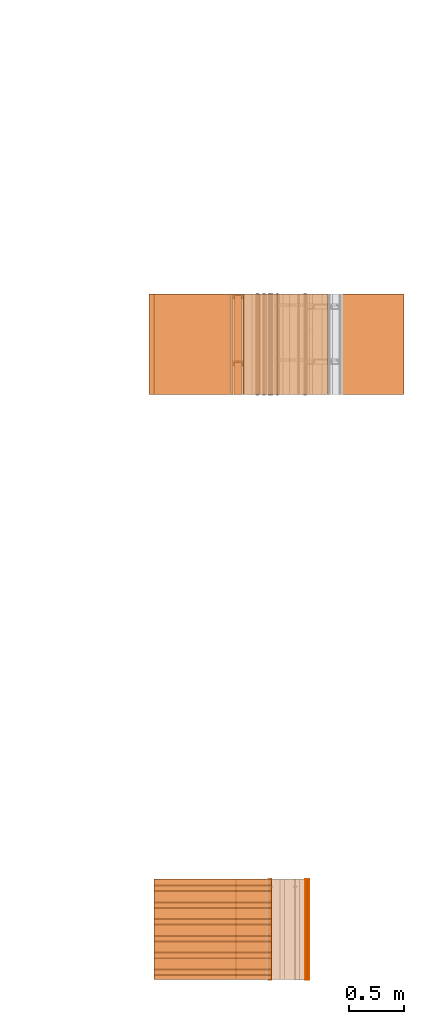
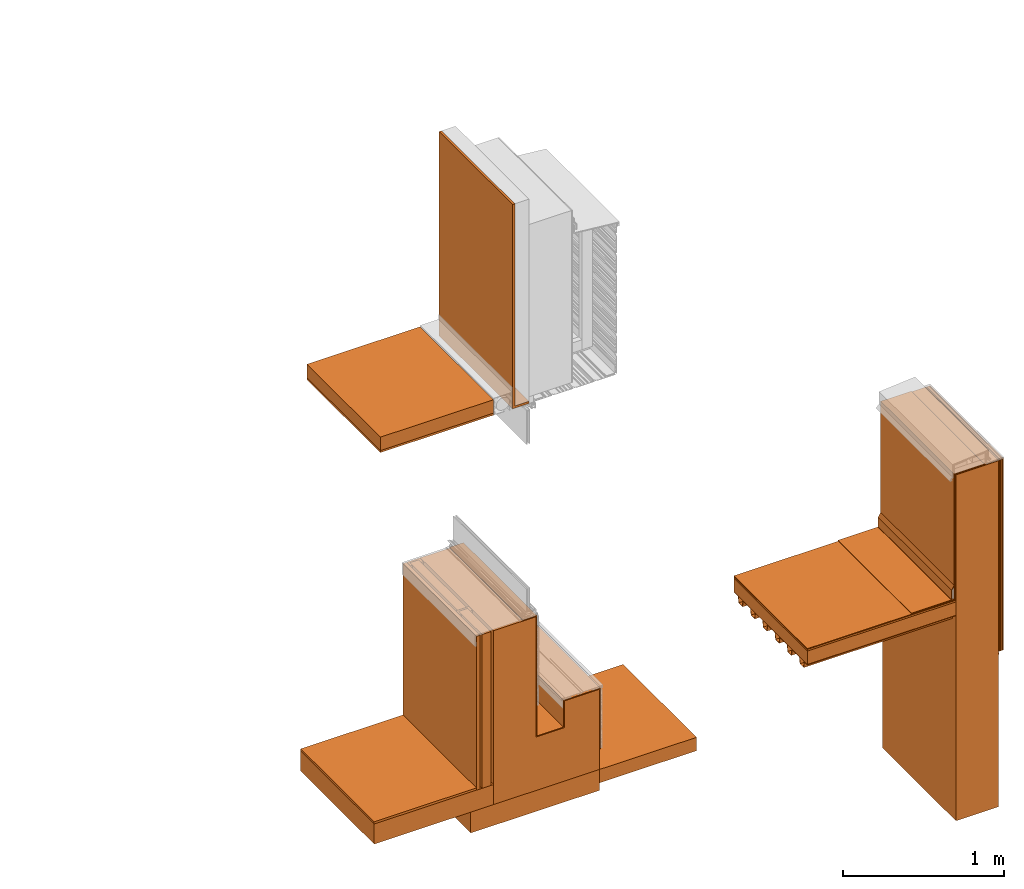
# One storey, part 1 of 36: 26 proxies.
"""IFC2X3 building model written with IfcOpenShell, lengths in feet."""

from ifc_helpers import new_model, entity, si_unit, converted_unit, derived_unit, direction, frame, frame_2d, origin, origin_2d_with_axis, place, context, subcontext, project, spatial, polyline, circle_curve, parameter, trimmed, segment, composite_curve, rectangle, outline, extrude, source, transform, mapped, material, type_object, type_shapes, element, save


model = new_model("IFC2X3")

# Units and contexts
model_context = context("Model", 3, precision=0.0001, world=origin(), true_north=direction((6.12303176911189e-17, 1.0)))
body_context = subcontext(model_context, "Body", "Model", "MODEL_VIEW")
ifc_project = project(units=[converted_unit("LENGTHUNIT", "FOOT", entity("IfcRatioMeasure", 0.3048), si_unit("LENGTHUNIT", "METRE"), dimensions=[1, 0, 0, 0, 0, 0, 0]), converted_unit("AREAUNIT", "SQUARE FOOT", entity("IfcRatioMeasure", 0.09290304), si_unit("AREAUNIT", "SQUARE_METRE"), dimensions=[2, 0, 0, 0, 0, 0, 0]), converted_unit("VOLUMEUNIT", "CUBIC FOOT", entity("IfcRatioMeasure", 0.028316846592), si_unit("VOLUMEUNIT", "CUBIC_METRE"), dimensions=[3, 0, 0, 0, 0, 0, 0]), converted_unit("PLANEANGLEUNIT", "DEGREE", entity("IfcRatioMeasure", 0.0174532925199433), si_unit("PLANEANGLEUNIT", "RADIAN"), dimensions=[0, 0, 0, 0, 0, 0, 0]), si_unit("MASSUNIT", "GRAM", prefix="KILO"), derived_unit("MASSDENSITYUNIT", [(si_unit("MASSUNIT", "GRAM", prefix="KILO"), 1), (si_unit("LENGTHUNIT", "METRE"), -3)]), si_unit("TIMEUNIT", "SECOND"), si_unit("FREQUENCYUNIT", "HERTZ"), si_unit("THERMODYNAMICTEMPERATUREUNIT", "DEGREE_CELSIUS"), derived_unit("THERMALTRANSMITTANCEUNIT", [(si_unit("MASSUNIT", "GRAM", prefix="KILO"), 1), (si_unit("THERMODYNAMICTEMPERATUREUNIT", "KELVIN"), -1), (si_unit("TIMEUNIT", "SECOND"), -3)]), derived_unit("VOLUMETRICFLOWRATEUNIT", [(si_unit("LENGTHUNIT", "METRE"), 3), (si_unit("TIMEUNIT", "SECOND"), -1)]), si_unit("ELECTRICCURRENTUNIT", "AMPERE"), si_unit("ELECTRICVOLTAGEUNIT", "VOLT"), si_unit("POWERUNIT", "WATT"), si_unit("FORCEUNIT", "NEWTON"), si_unit("ILLUMINANCEUNIT", "LUX"), si_unit("LUMINOUSFLUXUNIT", "LUMEN"), si_unit("LUMINOUSINTENSITYUNIT", "CANDELA"), derived_unit("USERDEFINED", [(si_unit("MASSUNIT", "GRAM", prefix="KILO"), -1), (si_unit("LENGTHUNIT", "METRE"), -2), (si_unit("TIMEUNIT", "SECOND"), 3), (si_unit("LUMINOUSFLUXUNIT", "LUMEN"), 1)]), derived_unit("LINEARVELOCITYUNIT", [(si_unit("LENGTHUNIT", "METRE"), 1), (si_unit("TIMEUNIT", "SECOND"), -1)]), si_unit("PRESSUREUNIT", "PASCAL"), derived_unit("USERDEFINED", [(si_unit("LENGTHUNIT", "METRE"), -2), (si_unit("MASSUNIT", "GRAM", prefix="KILO"), 1), (si_unit("TIMEUNIT", "SECOND"), -2)])], contexts=[model_context])

# Site, building, storey
site_placement = place(None, origin())
site = spatial("IfcSite", under=ifc_project, at=site_placement, CompositionType="ELEMENT")
building_placement = place(site_placement, origin())
building = spatial("IfcBuilding", under=site, at=building_placement, CompositionType="ELEMENT")
storey_placement = place(building_placement, origin())
storey = spatial("IfcBuildingStorey", under=building, at=storey_placement, Name="Level 1", CompositionType="ELEMENT", Elevation=0.0)

# Proxies
ifc_material_1 = material()
building_element_proxy_type_1 = type_object("IfcBuildingElementProxyType", PredefinedType="NOTDEFINED", material=ifc_material_1)
shared_shape_1 = source(origin(), body_context, "Body", "SweptSolid", [
    extrude(rectangle(XDim=2.99999999999999, YDim=3.50495130620079, at=frame_2d((7.105427357601e-15, -7.105427357601e-15), x_axis=(1.0, 0.0))), frame((121.624397761532, -80.1652000961286, 15.0), z_axis=(0.0, 0.0, 1.0), x_axis=(0.0, -1.0, 0.0)), (0.0, 0.0, 1.0), 0.333333333333337),
])
type_shapes(building_element_proxy_type_1, [shared_shape_1])
proxy_1_placement = place(storey_placement, origin())
element("IfcBuildingElementProxy", 1, at=proxy_1_placement, inside=storey, type_object=building_element_proxy_type_1, material=ifc_material_1, context=body_context, shape_type="MappedRepresentation", body=[
    mapped(shared_shape_1, transform((0.0, 0.0, 0.0), scale=1.0)),
])
ifc_material_2 = material(Name="_EXISTING CAST-IN-PLACE CONCRETE")
building_element_proxy_type_2 = type_object("IfcBuildingElementProxyType", PredefinedType="NOTDEFINED", material=ifc_material_2)
shared_shape_2 = source(origin(), body_context, "Body", "SweptSolid", [
    extrude(rectangle(XDim=2.99999999999999, YDim=0.999999999999986, at=frame_2d((7.105427357601e-15, 7.105427357601e-15), x_axis=(1.0, 0.0))), frame((123.876873414633, -80.1652000961286, 9.875), z_axis=(0.0, 0.0, 1.0), x_axis=(0.0, -1.0, 0.0)), (0.0, 0.0, 1.0), 8.625),
])
type_shapes(building_element_proxy_type_2, [shared_shape_2])
proxy_2_placement = place(storey_placement, origin())
element("IfcBuildingElementProxy", 2, at=proxy_2_placement, inside=storey, type_object=building_element_proxy_type_2, material=ifc_material_2, context=body_context, shape_type="MappedRepresentation", body=[
    mapped(shared_shape_2, transform((0.0, 0.0, 0.0), scale=1.0)),
])
building_element_proxy_type_3 = type_object("IfcBuildingElementProxyType", PredefinedType="NOTDEFINED", material=ifc_material_2)
shared_shape_3 = source(origin(), body_context, "Body", "SweptSolid", [
    extrude(outline(composite_curve([segment(polyline([(-2.14143887679974, -0.784598214307451), (-2.13102221013308, -0.784598214307451)]), True, "CONTINUOUS"), segment(polyline([(-2.13102221013308, -0.784598214307451), (-2.13102221013308, -0.0762648809741222)]), True, "CONTINUOUS"), segment(polyline([(-2.13102221013308, -0.0762648809741222), (0.63017533183543, -0.0762648809412951)]), True, "CONTINUOUS"), segment(polyline([(0.63017533183543, -0.0762648809412951), (0.733917958331489, -0.0163690476079665)]), True, "CONTINUOUS"), segment(polyline([(0.733917958331489, -0.0163690476079665), (0.959969644729002, -0.0163690476079665)]), True, "CONTINUOUS"), segment(trimmed(circle_curve(frame_2d((0.959969644729002, 0.00446428571936508), x_axis=(0.0, -1.0)), 0.0208333333333333), [parameter(0.0)], [parameter(90.0000000000001)], True, "PARAMETER"), True, "CONTINUOUS"), segment(polyline([(0.980802978062336, 0.00446428571936508), (0.980802978062462, 0.944568452392019)]), True, "CONTINUOUS"), segment(polyline([(0.980802978062462, 0.944568452392019), (0.970386311395799, 0.944568452392019)]), True, "CONTINUOUS"), segment(polyline([(0.970386311395799, 0.944568452392019), (0.970386311395799, 0.00446428571936508)]), True, "CONTINUOUS"), segment(trimmed(circle_curve(frame_2d((0.959969644729002, 0.00446428571936508), x_axis=(0.0, -1.0)), 0.0104166666666667), [parameter(0.0)], [parameter(90.0000000000001)], True, "PARAMETER"), False, "CONTINUOUS"), segment(polyline([(0.959969644729002, -0.00595238094730632), (0.731126820910234, -0.00595238094132355)]), True, "CONTINUOUS"), segment(polyline([(0.731126820910234, -0.00595238094132355), (0.627384194414171, -0.0658482142746379)]), True, "CONTINUOUS"), segment(polyline([(0.627384194414171, -0.0658482142746379), (-2.14143887679974, -0.0658482143074366)]), True, "CONTINUOUS"), segment(polyline([(-2.14143887679974, -0.0658482143074366), (-2.14143887679974, -0.784598214307451)]), True, "CONTINUOUS")], self_intersect=False)), frame((123.269358533659, -81.6652000961286, 16.3898111232003), z_axis=(0.0, 1.0, 0.0), x_axis=(0.0, 0.0, -1.0)), (0.0, 0.0, 1.0), 3.0),
])
type_shapes(building_element_proxy_type_3, [shared_shape_3])
proxy_3_placement = place(storey_placement, origin())
element("IfcBuildingElementProxy", 3, at=proxy_3_placement, inside=storey, type_object=building_element_proxy_type_3, material=ifc_material_2, context=body_context, shape_type="MappedRepresentation", body=[
    mapped(shared_shape_3, transform((0.0, 0.0, 0.0), scale=1.0)),
])
ifc_material_3 = material()
building_element_proxy_type_4 = type_object("IfcBuildingElementProxyType", PredefinedType="NOTDEFINED", material=ifc_material_3)
shared_shape_4 = source(origin(), body_context, "Body", "SweptSolid", [
    extrude(rectangle(XDim=0.0208333333333712, YDim=3.0, at=origin_2d_with_axis()), frame((123.366456747966, -80.1652000961286, 15.375), z_axis=(0.0, 0.0, 1.0), x_axis=(-1.0, 0.0, 0.0)), (0.0, 0.0, 1.0), 3.125),
])
type_shapes(building_element_proxy_type_4, [shared_shape_4])
proxy_4_placement = place(storey_placement, origin())
element("IfcBuildingElementProxy", 4, at=proxy_4_placement, inside=storey, type_object=building_element_proxy_type_4, material=ifc_material_3, context=body_context, shape_type="MappedRepresentation", body=[
    mapped(shared_shape_4, transform((0.0, 0.0, 0.0), scale=1.0)),
])
ifc_material_4 = material()
building_element_proxy_type_5 = type_object("IfcBuildingElementProxyType", PredefinedType="NOTDEFINED", material=ifc_material_4)
shared_shape_5 = source(origin(), body_context, "Body", "SweptSolid", [
    extrude(outline(polyline([(1.64442176403685, 0.957543218787396), (1.66517036318022, 0.957543218787396), (1.70388969748723, 0.984654788509743), (1.70090232021708, 0.988921205408832), (1.66352818199028, 0.962751552121041), (1.6427795828469, 0.962751552121037), (-2.27369147607305, -1.77959100308735), (-2.73388175054224, -1.12237117906065), (-2.73814816744133, -1.12535855633081), (-2.27497051570199, -1.7868447972566), (1.64442176403685, 0.957543218787396)])), frame((124.22325365897, -81.6652000961286, 15.627186180336), z_axis=(0.0, 1.0, 0.0), x_axis=(0.573576435870009, 0.0, -0.819152044625818)), (0.0, 0.0, 1.0), 3.0),
])
type_shapes(building_element_proxy_type_5, [shared_shape_5])
proxy_5_placement = place(storey_placement, origin())
element("IfcBuildingElementProxy", 5, at=proxy_5_placement, inside=storey, type_object=building_element_proxy_type_5, material=ifc_material_4, context=body_context, shape_type="MappedRepresentation", body=[
    mapped(shared_shape_5, transform((0.0, 0.0, 0.0), scale=1.0)),
])
building_element_proxy_type_6 = type_object("IfcBuildingElementProxyType", PredefinedType="NOTDEFINED", material=ifc_material_4)
shared_shape_6 = source(origin(), body_context, "Body", "SweptSolid", [
    extrude(rectangle(XDim=0.0156249999999858, YDim=2.99999999999999, at=frame_2d((7.105427357601e-15, 7.105427357601e-15), x_axis=(1.0, 0.0))), frame((124.473227581299, -80.1652000961286, 13.744164864019), z_axis=(0.0, 0.0, 1.0), x_axis=(-1.0, 0.0, 0.0)), (0.0, 0.0, 1.0), 4.7714601359811),
])
type_shapes(building_element_proxy_type_6, [shared_shape_6])
proxy_6_placement = place(storey_placement, origin())
element("IfcBuildingElementProxy", 6, at=proxy_6_placement, inside=storey, type_object=building_element_proxy_type_6, material=ifc_material_4, context=body_context, shape_type="MappedRepresentation", body=[
    mapped(shared_shape_6, transform((0.0, 0.0, 0.0), scale=1.0)),
])
ifc_material_5 = material()
building_element_proxy_type_7 = type_object("IfcBuildingElementProxyType", PredefinedType="NOTDEFINED", material=ifc_material_5)
shared_shape_7 = source(origin(), body_context, "Body", "SweptSolid", [
    extrude(rectangle(XDim=0.0196850393700885, YDim=2.99999999999999, at=frame_2d((7.105427357601e-15, 7.105427357601e-15), x_axis=(1.0, 0.0))), frame((124.490882600984, -80.1652000961286, 13.744164864019), z_axis=(0.0, 0.0, 1.0), x_axis=(-1.0, 0.0, 0.0)), (0.0, 0.0, 1.0), 4.7714601359811),
])
type_shapes(building_element_proxy_type_7, [shared_shape_7])
proxy_7_placement = place(storey_placement, origin())
element("IfcBuildingElementProxy", 7, at=proxy_7_placement, inside=storey, type_object=building_element_proxy_type_7, material=ifc_material_5, context=body_context, shape_type="MappedRepresentation", body=[
    mapped(shared_shape_7, transform((0.0, 0.0, 0.0), scale=1.0)),
])
ifc_material_6 = material()
building_element_proxy_type_8 = type_object("IfcBuildingElementProxyType", PredefinedType="NOTDEFINED", material=ifc_material_6)
shared_shape_8 = source(origin(), body_context, "Body", "SweptSolid", [
    extrude(rectangle(XDim=0.0416666666666714, YDim=2.99999999999999, at=frame_2d((7.105427357601e-15, 7.105427357601e-15), x_axis=(1.0, 0.0))), frame((124.444581747966, -80.1652000961286, 13.744164864019), z_axis=(0.0, 0.0, 1.0), x_axis=(-1.0, 0.0, 0.0)), (0.0, 0.0, 1.0), 4.7714601359811),
])
type_shapes(building_element_proxy_type_8, [shared_shape_8])
proxy_8_placement = place(storey_placement, origin())
element("IfcBuildingElementProxy", 8, at=proxy_8_placement, inside=storey, type_object=building_element_proxy_type_8, material=ifc_material_6, context=body_context, shape_type="MappedRepresentation", body=[
    mapped(shared_shape_8, transform((0.0, 0.0, 0.0), scale=1.0)),
])
ifc_material_7 = material()
building_element_proxy_type_9 = type_object("IfcBuildingElementProxyType", PredefinedType="NOTDEFINED", material=ifc_material_7)
shared_shape_9 = source(origin(), body_context, "Body", "SweptSolid", [
    extrude(rectangle(XDim=0.020833333333357, YDim=2.99999999999999, at=frame_2d((7.105427357601e-15, 7.105427357601e-15), x_axis=(1.0, 0.0))), frame((124.413331747966, -80.1652000961286, 13.744164864019), z_axis=(0.0, 0.0, 1.0), x_axis=(-1.0, 0.0, 0.0)), (0.0, 0.0, 1.0), 4.7714601359811),
])
type_shapes(building_element_proxy_type_9, [shared_shape_9])
proxy_9_placement = place(storey_placement, origin())
element("IfcBuildingElementProxy", 9, at=proxy_9_placement, inside=storey, type_object=building_element_proxy_type_9, material=ifc_material_7, context=body_context, shape_type="MappedRepresentation", body=[
    mapped(shared_shape_9, transform((0.0, 0.0, 0.0), scale=1.0)),
])
building_element_proxy_type_10 = type_object("IfcBuildingElementProxyType", PredefinedType="NOTDEFINED", material=ifc_material_7)
shared_shape_10 = source(origin(), body_context, "Body", "SweptSolid", [
    extrude(rectangle(XDim=0.020833333333357, YDim=2.99999999999999, at=frame_2d((-7.105427357601e-15, 7.105427357601e-15), x_axis=(1.0, 0.0))), frame((124.392498414633, -80.1652000961286, 13.744164864019), z_axis=(0.0, 0.0, 1.0), x_axis=(-1.0, 0.0, 0.0)), (0.0, 0.0, 1.0), 4.7714601359811),
])
type_shapes(building_element_proxy_type_10, [shared_shape_10])
proxy_10_placement = place(storey_placement, origin())
element("IfcBuildingElementProxy", 10, at=proxy_10_placement, inside=storey, type_object=building_element_proxy_type_10, material=ifc_material_7, context=body_context, shape_type="MappedRepresentation", body=[
    mapped(shared_shape_10, transform((0.0, 0.0, 0.0), scale=1.0)),
])
building_element_proxy_type_11 = type_object("IfcBuildingElementProxyType", Name="Generic Models 7:Generic Models 7", PredefinedType="NOTDEFINED", material=ifc_material_7)
shared_shape_11 = source(origin(), body_context, "Body", "SweptSolid", [
    extrude(outline(polyline([(-0.304129554411825, -1.1372250122797), (-0.332958090772665, -1.29097720620095), (-0.184783389742921, -1.34856737340409), (-0.206226270170879, -1.46292940235079), (-0.195988018223653, -1.46484907459094), (-0.172951951341912, -1.34199005122424), (-0.321126652371658, -1.28439988402109), (-0.295484488918378, -1.14764167893981), (-0.136511631537817, -1.14764167893981), (-0.0808076838149492, -0.850553957757426), (-0.228982384844695, -0.792963790554283), (-0.203340221391418, -0.656205585473014), (-0.0443673640108565, -0.656205585473014), (0.0113365837120136, -0.359117864290615), (-0.136838117317732, -0.301527697087473), (-0.111195953864455, -0.164769492006203), (0.0477769035161064, -0.164769492006204), (0.103480851238976, 0.132318229176195), (-0.0446938497907691, 0.189908396379337), (-0.0190516863374923, 0.326666601460607), (0.139921171043069, 0.326666601460607), (0.195625118765937, 0.623754322642991), (0.0474504177361911, 0.681344489846134), (0.0730925811894706, 0.818102694927417), (0.232065438570032, 0.818102694927417), (0.287769386292902, 1.11519041610982), (0.139594685263157, 1.17278058331296), (0.165236848716436, 1.30953878839424), (0.324209706096995, 1.30953878839423), (0.356877586938122, 1.48376748620991), (0.346639334990895, 1.48568715845005), (0.315564640603549, 1.31995545505436), (0.156591783222989, 1.31995545505436), (0.127763246862152, 1.16620326113312), (0.275937947891893, 1.10861309392996), (0.223420373076586, 0.828519361587546), (0.0644475156960263, 0.828519361587546), (0.0356189793351888, 0.674767167666309), (0.183793680364933, 0.617177000463167), (0.131276105549623, 0.337083268120735), (-0.0276967518309365, 0.337083268120735), (-0.056525288191774, 0.183331074199499), (0.0916494128379697, 0.125740906996357), (0.039131838022663, -0.154352825346061), (-0.119841019357897, -0.154352825346061), (-0.14866955571874, -0.308105019267325), (-0.000494854688995738, -0.365695186470467), (-0.0530124295043025, -0.645788918812885), (-0.21198528688486, -0.645788918812871), (-0.2408138232457, -0.799541112734122), (-0.092639122215956, -0.857131279937264), (-0.145156697031265, -1.1372250122797), (-0.304129554411825, -1.1372250122797)])), frame((119.871922108432, -80.1893223378911, 14.9226762820528), z_axis=(-1.0, 0.0, 0.0), x_axis=(0.0, 0.184288535053926, 0.982872186933621)), (0.0, 0.0, -1.0), 3.50495130618844),
])
type_shapes(building_element_proxy_type_11, [shared_shape_11])
proxy_11_placement = place(storey_placement, origin())
element("IfcBuildingElementProxy", 11, at=proxy_11_placement, inside=storey, type_object=building_element_proxy_type_11, material=ifc_material_7, ObjectType="Generic Models 7 : Generic Models 7:Generic Models 7", context=body_context, shape_type="MappedRepresentation", body=[
    mapped(shared_shape_11, transform((0.0, 0.0, 0.0), scale=1.0)),
])
building_element_proxy_type_12 = type_object("IfcBuildingElementProxyType", PredefinedType="NOTDEFINED", material=ifc_material_2)
shared_shape_12 = source(origin(), body_context, "Body", "SweptSolid", [
    extrude(rectangle(XDim=3.50495130620078, YDim=2.99999999999999, at=frame_2d((0.0, 7.105427357601e-15), x_axis=(1.0, 0.0))), frame((121.624397761532, -80.1652000961286, 15.3333333333333), z_axis=(0.0, 0.0, 1.0), x_axis=(-1.0, 0.0, 0.0)), (0.0, 0.0, 1.0), 0.0416666666666661),
])
type_shapes(building_element_proxy_type_12, [shared_shape_12])
proxy_12_placement = place(storey_placement, origin())
element("IfcBuildingElementProxy", 12, at=proxy_12_placement, inside=storey, type_object=building_element_proxy_type_12, material=ifc_material_2, context=body_context, shape_type="MappedRepresentation", body=[
    mapped(shared_shape_12, transform((0.0, 0.0, 0.0), scale=1.0)),
])
building_element_proxy_type_13 = type_object("IfcBuildingElementProxyType", PredefinedType="NOTDEFINED", material=ifc_material_2)
shared_shape_13 = source(origin(), body_context, "Body", "SweptSolid", [
    extrude(outline(composite_curve([segment(polyline([(-2.59746347963235, -0.0788704922763088), (-2.59746347963235, -0.0892871589429767)]), True, "CONTINUOUS"), segment(polyline([(-2.59746347963235, -0.0892871589429767), (0.855404493215005, -0.0892871589408841)]), True, "CONTINUOUS"), segment(trimmed(circle_curve(frame_2d((0.855404493215005, -0.0684538256075502), x_axis=(1.0, 0.0)), 0.0208333333333333), [parameter(270.0)], [parameter(0.0)], True, "PARAMETER"), True, "CONTINUOUS"), segment(polyline([(0.876237826535643, -0.0684538256075502), (0.876237826535643, 0.23661147682474)]), True, "CONTINUOUS"), segment(polyline([(0.876237826535643, 0.23661147682474), (0.865821159868986, 0.23661147682474)]), True, "CONTINUOUS"), segment(polyline([(0.865821159868986, 0.23661147682474), (0.865821159881676, -0.0684538256075502)]), True, "CONTINUOUS"), segment(trimmed(circle_curve(frame_2d((0.855404493215005, -0.0684538256075502), x_axis=(1.0, 0.0)), 0.0104166666666667), [parameter(270.0)], [parameter(0.0)], True, "PARAMETER"), False, "CONTINUOUS"), segment(polyline([(0.855404493215005, -0.0788704922763088), (-2.59746347963235, -0.0788704922763088)]), True, "CONTINUOUS")], self_intersect=False)), frame((122.469385588097, -81.6652000961286, 15.4723751039758), z_axis=(0.0, -1.0, 0.0), x_axis=(1.0, 0.0, 0.0)), (0.0, 0.0, -1.0), 3.0),
])
type_shapes(building_element_proxy_type_13, [shared_shape_13])
proxy_13_placement = place(storey_placement, origin())
element("IfcBuildingElementProxy", 13, at=proxy_13_placement, inside=storey, type_object=building_element_proxy_type_13, material=ifc_material_2, context=body_context, shape_type="MappedRepresentation", body=[
    mapped(shared_shape_13, transform((0.0, 0.0, 0.0), scale=1.0)),
])
building_element_proxy_type_14 = type_object("IfcBuildingElementProxyType", Name="Foundation block003", PredefinedType="NOTDEFINED", material=ifc_material_2)
shared_shape_14 = source(origin(), body_context, "Body", "SweptSolid", [
    extrude(rectangle(XDim=3.0, YDim=3.04223472971455, at=origin_2d_with_axis()), frame((123.522417672094, -62.7284331589239, -0.52083333333334), z_axis=(0.0, 0.0, 1.0), x_axis=(0.0, 1.0, 0.0)), (0.0, 0.0, 1.0), 0.52083333333334),
])
type_shapes(building_element_proxy_type_14, [shared_shape_14])
proxy_14_placement = place(storey_placement, origin())
element("IfcBuildingElementProxy", 14, at=proxy_14_placement, inside=storey, type_object=building_element_proxy_type_14, material=ifc_material_2, Name="Foundation block003:Foundation block003", ObjectType="Foundation block003", context=body_context, shape_type="MappedRepresentation", body=[
    mapped(shared_shape_14, transform((0.0, 0.0, 0.0), scale=1.0)),
])
building_element_proxy_type_15 = type_object("IfcBuildingElementProxyType", Name="Floor structure003", PredefinedType="NOTDEFINED", material=ifc_material_2)
shared_shape_15 = source(origin(), body_context, "Body", "SweptSolid", [
    extrude(rectangle(XDim=3.0, YDim=2.81767872375659, at=origin_2d_with_axis()), frame((121.134695675185, -62.7284331589239, 0.0), z_axis=(0.0, 0.0, 1.0), x_axis=(0.0, 1.0, 0.0)), (0.0, 0.0, 1.0), 0.500000000000003),
])
type_shapes(building_element_proxy_type_15, [shared_shape_15])
proxy_15_placement = place(storey_placement, origin())
element("IfcBuildingElementProxy", 15, at=proxy_15_placement, inside=storey, type_object=building_element_proxy_type_15, material=ifc_material_2, Name="Floor structure003:Floor structure003", ObjectType="Floor structure003", context=body_context, shape_type="MappedRepresentation", body=[
    mapped(shared_shape_15, transform((0.0, 0.0, 0.0), scale=1.0)),
])
building_element_proxy_type_16 = type_object("IfcBuildingElementProxyType", Name="Floor covering material003", PredefinedType="NOTDEFINED", material=ifc_material_2)
shared_shape_16 = source(origin(), body_context, "Body", "SweptSolid", [
    extrude(rectangle(XDim=3.0, YDim=2.41239199827757, at=origin_2d_with_axis()), frame((120.932052312446, -62.7284331589239, 0.500000000000003), z_axis=(0.0, 0.0, 1.0), x_axis=(0.0, 1.0, 0.0)), (0.0, 0.0, 1.0), 0.0564560977821521),
])
type_shapes(building_element_proxy_type_16, [shared_shape_16])
proxy_16_placement = place(storey_placement, origin())
element("IfcBuildingElementProxy", 16, at=proxy_16_placement, inside=storey, type_object=building_element_proxy_type_16, material=ifc_material_2, Name="Floor covering material003:Floor covering material003", ObjectType="Floor covering material003", context=body_context, shape_type="MappedRepresentation", body=[
    mapped(shared_shape_16, transform((0.0, 0.0, 0.0), scale=1.0)),
])
building_element_proxy_type_17 = type_object("IfcBuildingElementProxyType", Name="Sidewalk pavement003", PredefinedType="NOTDEFINED", material=ifc_material_2)
shared_shape_17 = source(origin(), body_context, "Body", "SweptSolid", [
    extrude(rectangle(XDim=3.0, YDim=2.28466369050525, at=origin_2d_with_axis()), frame((126.185866882313, -62.7284331589239, -0.333333333333327), z_axis=(0.0, 0.0, 1.0), x_axis=(0.0, 1.0, 0.0)), (0.0, 0.0, 1.0), 0.333333333333327),
])
type_shapes(building_element_proxy_type_17, [shared_shape_17])
proxy_17_placement = place(storey_placement, origin())
element("IfcBuildingElementProxy", 17, at=proxy_17_placement, inside=storey, type_object=building_element_proxy_type_17, material=ifc_material_2, Name="Sidewalk pavement003:Sidewalk pavement003", ObjectType="Sidewalk pavement003", context=body_context, shape_type="MappedRepresentation", body=[
    mapped(shared_shape_17, transform((0.0, 0.0, 0.0), scale=1.0)),
])
building_element_proxy_type_18 = type_object("IfcBuildingElementProxyType", Name="Concrete wall004", PredefinedType="NOTDEFINED", material=ifc_material_2)
shared_shape_18 = source(origin(), body_context, "Body", "SweptSolid", [
    extrude(outline(polyline([(-1.91666666666667, -1.29166666666669), (2.41666666666667, -1.29166666666669), (2.41666666666667, -0.291666666666657), (-0.583333333333333, -0.291666666666657), (-0.583333333333333, 0.375), (0.083333333333333, 0.375), (0.083333333333333, 1.20833333333331), (-1.91666666666667, 1.20833333333331), (-1.91666666666667, -1.29166666666669)])), frame((123.835201703727, -64.2284331589239, 1.91666666666667), z_axis=(0.0, 1.0, 0.0), x_axis=(0.0, 0.0, 1.0)), (0.0, 0.0, 1.0), 3.0),
])
type_shapes(building_element_proxy_type_18, [shared_shape_18])
proxy_18_placement = place(storey_placement, origin())
element("IfcBuildingElementProxy", 18, at=proxy_18_placement, inside=storey, type_object=building_element_proxy_type_18, material=ifc_material_2, Name="Concrete wall004:Concrete wall004", ObjectType="Concrete wall004", context=body_context, shape_type="MappedRepresentation", body=[
    mapped(shared_shape_18, transform((0.0, 0.0, 0.0), scale=1.0)),
])
building_element_proxy_type_19 = type_object("IfcBuildingElementProxyType", Name="WRB Membrane 009", PredefinedType="NOTDEFINED", material=ifc_material_4)
shared_shape_19 = source(origin(), body_context, "Body", "SweptSolid", [
    extrude(outline(polyline([(2.0625, -0.887214082583398), (2.08333333333333, -0.887214082583398), (2.08333333333333, -0.556992097347191), (-0.916666666666666, -0.556992097347191), (-0.916666666666666, 0.0680079026528091), (-0.25, 0.0680079026528091), (-0.25, 0.943007902652809), (-1.77083333333333, 0.943007902652809), (-1.77083333333333, 0.922174569319481), (-0.270833333333333, 0.922174569319481), (-0.270833333333333, 0.0888412359861661), (-0.9375, 0.0888412359861661), (-0.9375, -0.57782543068052), (2.0625, -0.57782543068052), (2.0625, -0.887214082583398)])), frame((124.121360467741, -64.2284331589238, 2.27083333333333), z_axis=(0.0, 1.0, 0.0), x_axis=(0.0, 0.0, 1.0)), (0.0, 0.0, 1.0), 3.0),
])
type_shapes(building_element_proxy_type_19, [shared_shape_19])
proxy_19_placement = place(storey_placement, origin())
element("IfcBuildingElementProxy", 19, at=proxy_19_placement, inside=storey, type_object=building_element_proxy_type_19, material=ifc_material_4, Name="Membrane 009:Membrane 009", ObjectType="WRB Membrane 009", context=body_context, shape_type="MappedRepresentation", body=[
    mapped(shared_shape_19, transform((0.0, 0.0, 0.0), scale=1.0)),
])
ifc_material_8 = material(Name="Rigid insulation")
building_element_proxy_type_20 = type_object("IfcBuildingElementProxyType", Name="Insulation003", PredefinedType="NOTDEFINED", material=ifc_material_8)
shared_shape_20 = source(origin(), body_context, "Body", "SweptSolid", [
    extrude(rectangle(XDim=3.0, YDim=0.208333333333357, at=frame_2d((0.0, 7.105427357601e-15), x_axis=(1.0, 0.0))), frame((122.374735405499, -62.7284331589239, 0.5), z_axis=(0.0, 0.0, 1.0), x_axis=(0.0, 1.0, 0.0)), (0.0, 0.0, 1.0), 3.83333333333333),
])
type_shapes(building_element_proxy_type_20, [shared_shape_20])
proxy_20_placement = place(storey_placement, origin())
element("IfcBuildingElementProxy", 20, at=proxy_20_placement, inside=storey, type_object=building_element_proxy_type_20, material=ifc_material_8, Name="Insulation003:Insulation003", ObjectType="Insulation003", context=body_context, shape_type="MappedRepresentation", body=[
    mapped(shared_shape_20, transform((0.0, 0.0, 0.0), scale=1.0)),
])
ifc_material_9 = material(Name="METAL STUDS")
building_element_proxy_type_21 = type_object("IfcBuildingElementProxyType", Name="Metal stud006", PredefinedType="NOTDEFINED", material=ifc_material_9)
shared_shape_21 = source(origin(), body_context, "Body", "SweptSolid", [
    extrude(outline(polyline([(-0.0644366447096445, -0.106770833333314), (-0.0644366447096445, -0.1484375), (0.0876338087680395, -0.1484375), (0.0876338087680395, 0.153645833333343), (-0.0644366447096445, 0.153645833333343), (-0.0644366447096445, 0.1015625), (0.0412394806512424, 0.1015625), (0.0412394806512424, -0.106770833333314), (-0.0644366447096445, -0.106770833333314)])), frame((122.377339572084, -61.3160669676919, 0.499999999999678), z_axis=(0.0, 0.0, -1.0), x_axis=(0.0, 1.0, 0.0)), (0.0, 0.0, -1.0), 3.83333333333333),
])
type_shapes(building_element_proxy_type_21, [shared_shape_21])
proxy_21_placement = place(storey_placement, origin())
element("IfcBuildingElementProxy", 21, at=proxy_21_placement, inside=storey, type_object=building_element_proxy_type_21, material=ifc_material_9, Name="Metal stud006:Metal stud006", ObjectType="Metal stud006", context=body_context, shape_type="MappedRepresentation", body=[
    mapped(shared_shape_21, transform((0.0, 0.0, 0.0), scale=1.0)),
])
building_element_proxy_type_22 = type_object("IfcBuildingElementProxyType", Name="Metal stud007", PredefinedType="NOTDEFINED", material=ifc_material_9)
shared_shape_22 = source(origin(), body_context, "Body", "SweptSolid", [
    extrude(outline(polyline([(-0.0644366447096445, -0.106770833333314), (-0.0644366447096445, -0.1484375), (0.0876338087680395, -0.1484375), (0.0876338087680395, 0.153645833333343), (-0.0644366447096445, 0.153645833333343), (-0.0644366447096445, 0.1015625), (0.0412394806512424, 0.1015625), (0.0412394806512424, -0.106770833333314), (-0.0644366447096445, -0.106770833333314)])), frame((122.377339572084, -63.3160669676919, 0.499999999999678), z_axis=(0.0, 0.0, -1.0), x_axis=(0.0, 1.0, 0.0)), (0.0, 0.0, -1.0), 3.83333333333333),
])
type_shapes(building_element_proxy_type_22, [shared_shape_22])
proxy_22_placement = place(storey_placement, origin())
element("IfcBuildingElementProxy", 22, at=proxy_22_placement, inside=storey, type_object=building_element_proxy_type_22, material=ifc_material_9, Name="Metal stud007:Metal stud007", ObjectType="Metal stud007", context=body_context, shape_type="MappedRepresentation", body=[
    mapped(shared_shape_22, transform((0.0, 0.0, 0.0), scale=1.0)),
])
building_element_proxy_type_23 = type_object("IfcBuildingElementProxyType", Name="Gypsum panel 002", PredefinedType="NOTDEFINED", material=ifc_material_2)
shared_shape_23 = source(origin(), body_context, "Body", "SweptSolid", [
    extrude(rectangle(XDim=3.0, YDim=0.0820456841361477, at=origin_2d_with_axis()), frame((122.179271153735, -62.7284331589239, 0.5), z_axis=(0.0, 0.0, 1.0), x_axis=(0.0, 1.0, 0.0)), (0.0, 0.0, 1.0), 3.83333333333333),
])
type_shapes(building_element_proxy_type_23, [shared_shape_23])
proxy_23_placement = place(storey_placement, origin())
element("IfcBuildingElementProxy", 23, at=proxy_23_placement, inside=storey, type_object=building_element_proxy_type_23, material=ifc_material_2, Name="Gypsum panel 002:Gypsum panel 002", ObjectType="Gypsum panel 002", context=body_context, shape_type="MappedRepresentation", body=[
    mapped(shared_shape_23, transform((0.0, 0.0, 0.0), scale=1.0)),
])
building_element_proxy_type_24 = type_object("IfcBuildingElementProxyType", Name="Inner gypsum board003", PredefinedType="NOTDEFINED", material=ifc_material_2)
shared_shape_24 = source(origin(), body_context, "Body", "SweptSolid", [
    extrude(outline(polyline([(-0.0937483186701513, 1.66319433764217), (0.239579970591649, 1.66319433764217), (0.239579970591649, 1.7152779913692), (-0.145831651839444, 1.7152779913692), (-0.14583165200348, -3.37847232901138), (-0.0937483186701513, -3.37847232901138), (-0.0937483186701513, 1.66319433764217)])), frame((123.137288399858, -64.2284331589239, 11.4236113247157), z_axis=(0.0, 1.0, 0.0), x_axis=(1.0, 0.0, 0.0)), (0.0, 0.0, 1.0), 3.0),
])
type_shapes(building_element_proxy_type_24, [shared_shape_24])
proxy_24_placement = place(storey_placement, origin())
element("IfcBuildingElementProxy", 24, at=proxy_24_placement, inside=storey, type_object=building_element_proxy_type_24, material=ifc_material_2, Name="Inner gypsum board003:Inner gypsum board003", ObjectType="Inner gypsum board003", context=body_context, shape_type="MappedRepresentation", body=[
    mapped(shared_shape_24, transform((0.0, 0.0, 0.0), scale=1.0)),
])
building_element_proxy_type_25 = type_object("IfcBuildingElementProxyType", Name="Inner ceiling003", PredefinedType="NOTDEFINED", material=ifc_material_2)
shared_shape_25 = source(origin(), body_context, "Body", "SweptSolid", [
    extrude(rectangle(XDim=3.0, YDim=2.66666666666666, at=frame_2d((0.0, -1.4210854715202e-14), x_axis=(1.0, 0.0))), frame((121.205250397297, -62.7284331589239, 9.70833333333333), z_axis=(0.0, 0.0, 1.0), x_axis=(0.0, 1.0, 0.0)), (0.0, 0.0, 1.0), 0.0520833333333339),
])
type_shapes(building_element_proxy_type_25, [shared_shape_25])
proxy_25_placement = place(storey_placement, origin())
element("IfcBuildingElementProxy", 25, at=proxy_25_placement, inside=storey, type_object=building_element_proxy_type_25, material=ifc_material_2, Name="Inner ceiling003:Inner ceiling003", ObjectType="Inner ceiling003", context=body_context, shape_type="MappedRepresentation", body=[
    mapped(shared_shape_25, transform((0.0, 0.0, 0.0), scale=1.0)),
])
building_element_proxy_type_26 = type_object("IfcBuildingElementProxyType", Name="Insulation horizontal003", PredefinedType="NOTDEFINED", material=ifc_material_2)
shared_shape_26 = source(origin(), body_context, "Body", "SweptSolid", [
    extrude(rectangle(XDim=3.0, YDim=2.66666666666666, at=frame_2d((0.0, -1.4210854715202e-14), x_axis=(1.0, 0.0))), frame((121.205250397297, -62.7284331589239, 9.76041666666666), z_axis=(0.0, 0.0, 1.0), x_axis=(0.0, 1.0, 0.0)), (0.0, 0.0, 1.0), 0.333333333333334),
])
type_shapes(building_element_proxy_type_26, [shared_shape_26])
proxy_26_placement = place(storey_placement, origin())
element("IfcBuildingElementProxy", 26, at=proxy_26_placement, inside=storey, type_object=building_element_proxy_type_26, material=ifc_material_2, Name="Insulation horizontal003:Insulation horizontal003", ObjectType="Insulation horizontal003", context=body_context, shape_type="MappedRepresentation", body=[
    mapped(shared_shape_26, transform((0.0, 0.0, 0.0), scale=1.0)),
])

save(model, "model.ifc")
